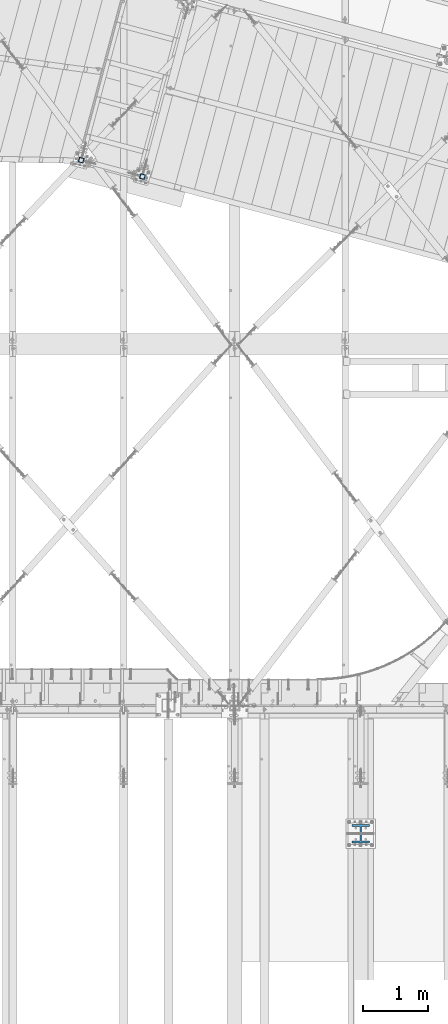
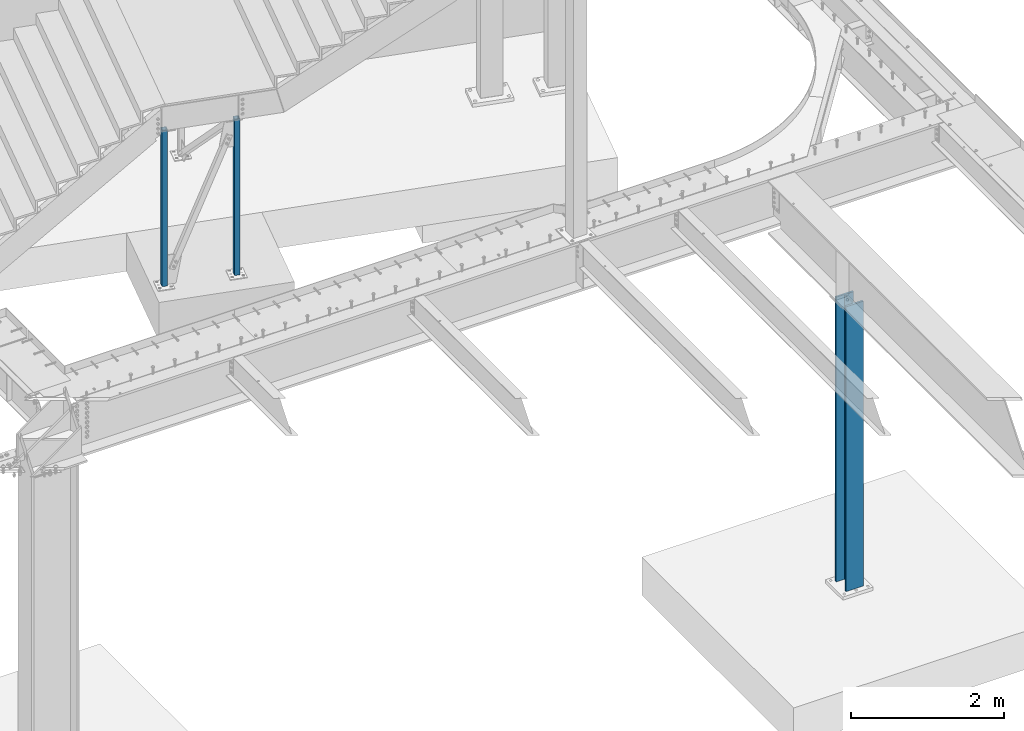
# One storey, part 915 of 1763: 3 columns, 3 elements without a shape of their own.
"""IFC2X3 building model written with IfcOpenShell, lengths in millimetres."""

from ifc_helpers import new_model, si_unit, frame, origin_with_axes, place, context, subcontext, project, spatial, faceted_brep, material, type_object, element, aggregate, save


model = new_model("IFC2X3")

# Units and contexts
model_context = context("Model", 3, precision=1e-05, world=origin_with_axes())
body_context = subcontext(model_context, "Body", "Model", "MODEL_VIEW")
ifc_project = project(units=[si_unit("LENGTHUNIT", "METRE", prefix="MILLI"), si_unit("AREAUNIT", "SQUARE_METRE"), si_unit("VOLUMEUNIT", "CUBIC_METRE"), si_unit("MASSUNIT", "GRAM", prefix="KILO"), si_unit("TIMEUNIT", "SECOND"), si_unit("PLANEANGLEUNIT", "RADIAN"), si_unit("SOLIDANGLEUNIT", "STERADIAN"), si_unit("THERMODYNAMICTEMPERATUREUNIT", "DEGREE_CELSIUS"), si_unit("LUMINOUSINTENSITYUNIT", "LUMEN")], contexts=[model_context])

# Site, building, storey
site_placement = place(None, origin_with_axes())
site = spatial("IfcSite", under=ifc_project, at=site_placement, CompositionType="ELEMENT")
building_placement = place(site_placement, origin_with_axes())
building = spatial("IfcBuilding", under=site, at=building_placement, Name="Undefined", CompositionType="ELEMENT")
storey_placement = place(building_placement, origin_with_axes())
storey = spatial("IfcBuildingStorey", under=building, at=storey_placement, Name="Undefined", CompositionType="ELEMENT", Elevation=0.0)

# Assembly, column
assembly_1_placement = place(storey_placement, origin_with_axes())
assembly_1 = element("IfcElementAssembly", 1, at=assembly_1_placement, inside=storey, Name="COLUMN", AssemblyPlace="NOTDEFINED", PredefinedType="RIGID_FRAME")
ifc_material_1 = material()
column_type_1 = type_object("IfcColumnType", Name="HSS3X3X1/4", PredefinedType="NOTDEFINED")
column_1_placement = place(assembly_1_placement, frame((-27401.0034883434, 60290.3031840951, -304.800000028329), z_axis=(-0.965925827679309, 0.258819039914073, 0.0), x_axis=(0.0, 0.0, 1.0)))
column_1 = element("IfcColumn", 2, at=column_1_placement, type_object=column_type_1, material=ifc_material_1, Name="COLUMN", ObjectType="HSS3X3X1/4", context=body_context, shape_type="Brep", body=[
    faceted_brep([(50.8000000000044, 31.7500000001673, -31.7499999999709), (50.8000000000044, -31.7500000000291, -31.7499999999272), (2540.00000008273, -31.7500000000291, -31.7499999999272), (2540.00000008273, 31.7500000001673, -31.7499999999709), (50.8000000000044, -31.7500000001601, 31.7499999999854), (2540.00000008273, -31.7500000001601, 31.7499999999854), (50.8000000000044, 31.7500000000509, 31.7499999999418), (2540.00000008273, 31.7500000000509, 31.7499999999418), (50.8000000000044, 38.100000000195, -38.0999999999694), (50.8000000000044, 38.1000000000495, 38.0999999999331), (2540.00000008273, 38.1000000000495, 38.0999999999331), (2540.00000008273, 38.100000000195, -38.0999999999694), (50.8000000000044, -38.1000000001804, 38.099999999984), (2540.00000008273, -38.1000000001804, 38.099999999984), (50.8000000000044, -38.1000000000349, -38.0999999999112), (2540.00000008273, -38.1000000000349, -38.0999999999112)], [[[0, 1, 2, 3]], [[1, 4, 5, 2]], [[4, 6, 7, 5]], [[6, 0, 3, 7]], [[8, 9, 10, 11]], [[9, 12, 13, 10]], [[12, 14, 15, 13]], [[14, 8, 11, 15]], [[13, 15, 11, 10], [5, 7, 3, 2]], [[14, 12, 9, 8], [6, 4, 1, 0]]]),
])
aggregate(assembly_1, [column_1])

assembly_2_placement = place(storey_placement, origin_with_axes())
assembly_2 = element("IfcElementAssembly", 3, at=assembly_2_placement, inside=storey, Name="COLUMN", AssemblyPlace="NOTDEFINED", PredefinedType="RIGID_FRAME")
column_2_placement = place(assembly_2_placement, frame((-28345.5700722532, 60543.4481594669, -304.800000028328), z_axis=(-0.965925827679309, 0.258819039914073, 0.0), x_axis=(0.0, 0.0, 1.0)))
column_2 = element("IfcColumn", 4, at=column_2_placement, type_object=column_type_1, material=ifc_material_1, Name="COLUMN", ObjectType="HSS3X3X1/4", context=body_context, shape_type="Brep", body=[
    faceted_brep([(50.8000000000044, 31.7500000001673, -31.7499999999709), (50.8000000000044, -31.7500000000291, -31.7499999999272), (2540.00000008273, -31.7500000000291, -31.7499999999272), (2540.00000008273, 31.7500000001673, -31.7499999999709), (50.8000000000044, -31.7500000001601, 31.7499999999854), (2540.00000008273, -31.7500000001601, 31.7499999999854), (50.8000000000044, 31.7500000000509, 31.7499999999418), (2540.00000008273, 31.7500000000509, 31.7499999999418), (50.8000000000044, 38.100000000195, -38.0999999999694), (50.8000000000044, 38.1000000000495, 38.0999999999331), (2540.00000008273, 38.1000000000495, 38.0999999999331), (2540.00000008273, 38.100000000195, -38.0999999999694), (50.8000000000044, -38.1000000001804, 38.099999999984), (2540.00000008273, -38.1000000001804, 38.099999999984), (50.8000000000044, -38.1000000000349, -38.0999999999112), (2540.00000008273, -38.1000000000349, -38.0999999999112)], [[[0, 1, 2, 3]], [[1, 4, 5, 2]], [[4, 6, 7, 5]], [[6, 0, 3, 7]], [[8, 9, 10, 11]], [[9, 12, 13, 10]], [[12, 14, 15, 13]], [[14, 8, 11, 15]], [[13, 15, 11, 10], [5, 7, 3, 2]], [[14, 12, 9, 8], [6, 4, 1, 0]]]),
])
aggregate(assembly_2, [column_2])

assembly_3_placement = place(storey_placement, origin_with_axes())
assembly_3 = element("IfcElementAssembly", 5, at=assembly_3_placement, inside=storey, Name="COLUMN", AssemblyPlace="NOTDEFINED", PredefinedType="RIGID_FRAME")
ifc_material_2 = material(Name="STEEL/A992")
column_type_2 = type_object("IfcColumnType", Name="W10X100", PredefinedType="NOTDEFINED")
column_3_placement = place(assembly_3_placement, frame((-24027.8372736984, 50139.6, -304.8), z_axis=(0.0, 1.0, 0.0), x_axis=(0.0, 0.0, 1.0)))
column_3 = element("IfcColumn", 6, at=column_3_placement, type_object=column_type_2, material=ifc_material_2, Name="COLUMN", ObjectType="W10X100", context=body_context, shape_type="Brep", body=[
    faceted_brep([(88.9000000000079, 131.762499999997, -141.287499999999), (88.9000000000079, 131.762499999997, -112.712500000001), (4625.975, 131.762500000001, -112.712500000001), (4625.975, 131.762500000001, -141.287499999999), (88.9000000000079, 8.73124999999709, -112.712500000001), (4625.975, 8.73125000000073, -112.712500000001), (88.9000000000079, 8.73124999999709, 112.712500000001), (4625.975, 8.73125000000073, 112.712500000001), (88.9000000000079, 131.762499999997, 112.712500000001), (4625.975, 131.762500000001, 112.712500000001), (88.9000000000079, 131.762499999997, 141.287499999999), (4625.975, 131.762500000001, 141.287499999999), (88.9000000000079, -131.762499999997, 141.287499999999), (4625.975, -131.762500000001, 141.287499999999), (88.9000000000079, -131.762499999997, 112.712500000001), (4625.975, -131.762500000001, 112.712500000001), (88.9000000000079, -8.73124999999709, 112.712500000001), (4625.975, -8.73125000000073, 112.712500000001), (88.9000000000079, -8.73124999999709, -112.712500000001), (4625.975, -8.73125000000073, -112.712500000001), (88.9000000000079, -131.762499999997, -112.712500000001), (4625.975, -131.762500000001, -112.712500000001), (88.9000000000079, -131.762499999997, -141.287499999999), (4625.975, -131.762500000001, -141.287499999999)], [[[0, 1, 2, 3]], [[1, 4, 5, 2]], [[4, 6, 7, 5]], [[6, 8, 9, 7]], [[8, 10, 11, 9]], [[10, 12, 13, 11]], [[12, 14, 15, 13]], [[14, 16, 17, 15]], [[16, 18, 19, 17]], [[18, 20, 21, 19]], [[20, 22, 23, 21]], [[22, 0, 3, 23]], [[5, 7, 9, 11, 13, 15, 17, 19, 21, 23, 3, 2]], [[22, 20, 18, 16, 14, 12, 10, 8, 6, 4, 1, 0]]]),
])
aggregate(assembly_3, [column_3])

save(model, "model.ifc")
